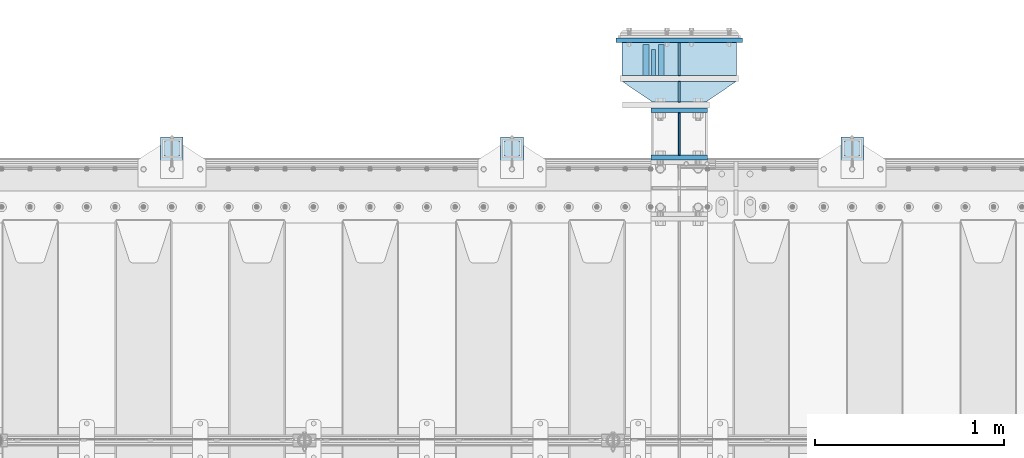
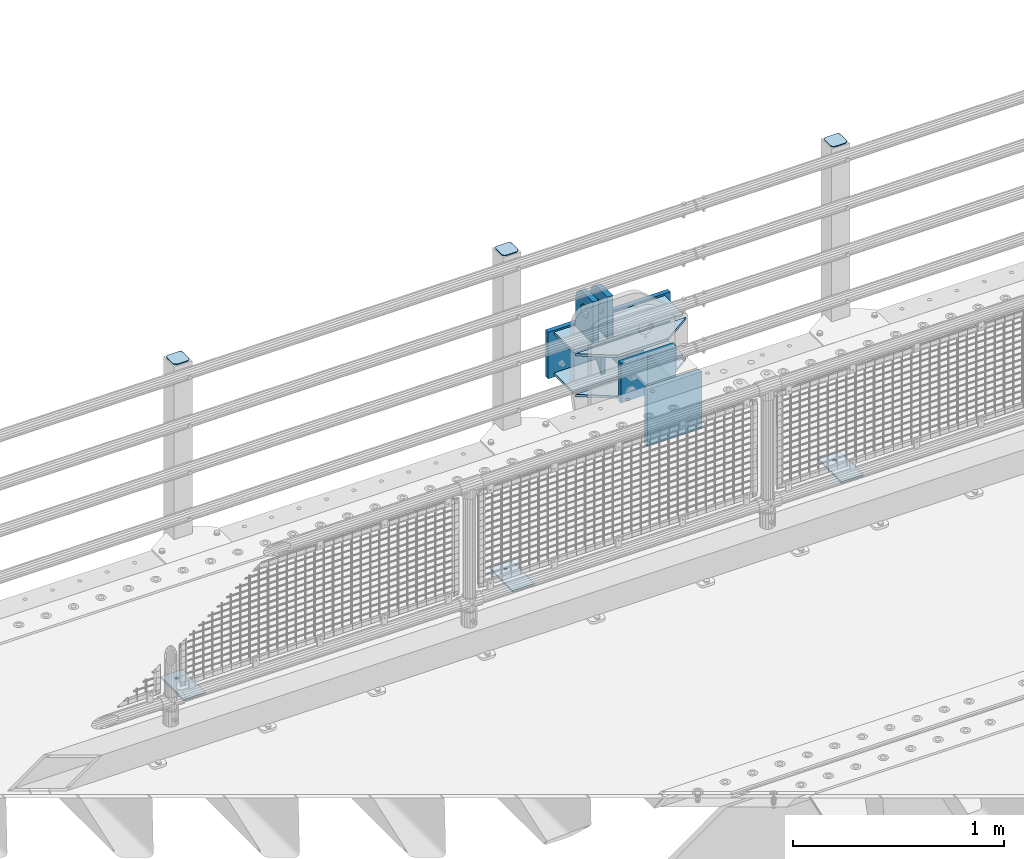
# One storey, part 239 of 270: 19 plates.
"""IFC2X3 building model written with IfcOpenShell, lengths in millimetres."""

from ifc_helpers import new_model, si_unit, frame, origin_with_axes, place, context, subcontext, project, spatial, faceted_brep, material, type_object, element, save


model = new_model("IFC2X3")

# Units and contexts
model_context = context("Model", 3, precision=1e-05, world=origin_with_axes())
body_context = subcontext(model_context, "Body", "Model", "MODEL_VIEW")
ifc_project = project(units=[si_unit("LENGTHUNIT", "METRE", prefix="MILLI"), si_unit("AREAUNIT", "SQUARE_METRE"), si_unit("VOLUMEUNIT", "CUBIC_METRE"), si_unit("MASSUNIT", "GRAM", prefix="KILO"), si_unit("TIMEUNIT", "SECOND"), si_unit("PLANEANGLEUNIT", "RADIAN"), si_unit("SOLIDANGLEUNIT", "STERADIAN"), si_unit("THERMODYNAMICTEMPERATUREUNIT", "DEGREE_CELSIUS"), si_unit("LUMINOUSINTENSITYUNIT", "LUMEN")], contexts=[model_context])

# Site, building, storey
site_placement = place(None, origin_with_axes())
site = spatial("IfcSite", under=ifc_project, at=site_placement, CompositionType="ELEMENT")
building_placement = place(site_placement, origin_with_axes())
building = spatial("IfcBuilding", under=site, at=building_placement, Name="Standard", CompositionType="ELEMENT")
storey_placement = place(building_placement, origin_with_axes())
storey = spatial("IfcBuildingStorey", under=building, at=storey_placement, Name="Undefined", CompositionType="ELEMENT", Elevation=0.0)

# Plates
ifc_material_1 = material(Name="STEEL/S355N")
plate_type_1 = type_object("IfcPlateType", PredefinedType="NOTDEFINED")
plate_1_placement = place(storey_placement, frame((13884.9999999931, -14837.4999999546, -350.000018205628), z_axis=(0.0, 0.0, 1.0), x_axis=(1.0, 0.0, 0.0)))
element("IfcPlate", 1, at=plate_1_placement, inside=storey, type_object=plate_type_1, material=ifc_material_1, context=body_context, shape_type="Brep", body=[
    faceted_brep([(0.0, -12.5, 0.0), (0.0, -12.5, 330.0), (0.0, 12.5, 330.0), (0.0, 12.5, 0.0), (300.0, -12.5, 330.0), (300.0, 12.5, 330.0), (300.0, -12.5, 0.0), (300.0, 12.5, 0.0)], [[[0, 1, 2, 3]], [[1, 4, 5, 2]], [[4, 6, 7, 5]], [[6, 0, 3, 7]], [[5, 7, 3, 2]], [[6, 4, 1, 0]]]),
])
plate_type_2 = type_object("IfcPlateType", PredefinedType="NOTDEFINED")
plate_2_placement = place(storey_placement, frame((14034.9999999931, -14824.9999999546, -346.000018205628), z_axis=(0.0, 1.0, 0.0), x_axis=(0.0, 0.0, 1.0)))
element("IfcPlate", 2, at=plate_2_placement, inside=storey, type_object=plate_type_2, material=ifc_material_1, context=body_context, shape_type="Brep", body=[
    faceted_brep([(0.0, -5.0, 0.0), (100.0, -5.0, 225.0), (100.0, 5.0, 225.0), (0.0, 5.0, 0.0), (322.0, -5.0, 225.0), (322.0, 5.0, 225.0), (322.0, -5.0, 0.0), (322.0, 5.0, 0.0)], [[[0, 1, 2, 3]], [[1, 4, 5, 2]], [[4, 6, 7, 5]], [[6, 0, 3, 7]], [[5, 7, 3, 2]], [[6, 4, 1, 0]]]),
])
plate_type_3 = type_object("IfcPlateType", PredefinedType="NOTDEFINED")
plate_3_placement = place(storey_placement, frame((13859.4999999931, -14404.9999999546, -10.0000182056285), z_axis=(0.0, 1.0, 0.0), x_axis=(0.0, 0.0, 1.0)))
element("IfcPlate", 3, at=plate_3_placement, inside=storey, type_object=plate_type_3, material=ifc_material_1, context=body_context, shape_type="Brep", body=[
    faceted_brep([(125.840713002492, 15.0, 114.183542702918), (125.840713002492, -15.0, 114.183542702918), (113.837049096098, -15.0, 106.162950903903), (113.837049096098, 15.0, 106.162950903903), (105.816457297082, -15.0, 94.1592869975084), (105.816457297082, 15.0, 94.1592869975084), (103.0, -15.0, 80.0), (103.0, 15.0, 80.0), (105.816457297082, -15.0, 65.8407130024916), (105.816457297082, 15.0, 65.8407130024916), (113.837049096098, -15.0, 53.837049096097), (113.837049096098, 15.0, 53.837049096097), (125.840713002492, -15.0, 45.8164572970818), (125.840713002492, 15.0, 45.8164572970818), (140.0, -15.0, 43.0), (140.0, 15.0, 43.0), (154.159286997508, -15.0, 45.8164572970818), (154.159286997508, 15.0, 45.8164572970818), (166.162950903902, -15.0, 53.837049096097), (166.162950903902, 15.0, 53.837049096097), (174.183542702918, -15.0, 65.8407130024916), (174.183542702918, 15.0, 65.8407130024916), (177.0, -15.0, 80.0), (177.0, 15.0, 80.0), (174.183542702918, -15.0, 94.1592869975084), (174.183542702918, 15.0, 94.1592869975084), (166.162950903902, -15.0, 106.162950903903), (166.162950903902, 15.0, 106.162950903903), (154.159286997508, -15.0, 114.183542702918), (154.159286997508, 15.0, 114.183542702918), (140.0, -15.0, 117.0), (140.0, 15.0, 117.0), (0.0, -15.0, 165.0), (170.0, -15.0, 165.0), (170.0, 15.0, 165.0), (0.0, 15.0, 165.0), (188.117333157176, -15.0, 162.614807840235), (188.117333157176, 15.0, 162.614807840235), (205.0, -15.0, 155.621778264911), (205.0, 15.0, 155.621778264911), (219.497474683058, -15.0, 144.497474683058), (219.497474683058, 15.0, 144.497474683058), (230.621778264911, -15.0, 130.0), (230.621778264911, 15.0, 130.0), (237.614807840235, -15.0, 113.117333157177), (237.614807840235, 15.0, 113.117333157177), (240.0, -15.0, 95.0), (240.0, 15.0, 95.0), (240.0, -15.0, 0.0), (240.0, 15.0, 0.0), (0.0, -15.0, 0.0), (0.0, 15.0, 0.0)], [[[0, 1, 2, 3]], [[3, 2, 4, 5]], [[5, 4, 6, 7]], [[7, 6, 8, 9]], [[9, 8, 10, 11]], [[11, 10, 12, 13]], [[13, 12, 14, 15]], [[15, 14, 16, 17]], [[17, 16, 18, 19]], [[19, 18, 20, 21]], [[21, 20, 22, 23]], [[23, 22, 24, 25]], [[25, 24, 26, 27]], [[27, 26, 28, 29]], [[29, 28, 30, 31]], [[31, 30, 1, 0]], [[32, 33, 34, 35]], [[33, 36, 37, 34]], [[36, 38, 39, 37]], [[38, 40, 41, 39]], [[40, 42, 43, 41]], [[42, 44, 45, 43]], [[44, 46, 47, 45]], [[46, 48, 49, 47]], [[48, 50, 51, 49]], [[34, 37, 39, 41, 43, 45, 47, 49, 51, 35], [3, 5, 7, 9, 11, 13, 15, 17, 19, 21, 23, 25, 27, 29, 31, 0]], [[50, 32, 35, 51]], [[48, 46, 44, 42, 40, 38, 36, 33, 32, 50], [26, 24, 22, 20, 18, 16, 14, 12, 10, 8, 6, 4, 2, 1, 30, 28]]]),
])
plate_4_placement = place(storey_placement, frame((13939.4999999931, -14404.9999999546, -10.0000182056285), z_axis=(0.0, 1.0, 0.0), x_axis=(0.0, 0.0, 1.0)))
element("IfcPlate", 4, at=plate_4_placement, inside=storey, type_object=plate_type_3, material=ifc_material_1, context=body_context, shape_type="Brep", body=[
    faceted_brep([(125.840713002492, 15.0, 114.183542702918), (125.840713002492, -15.0, 114.183542702918), (113.837049096098, -15.0, 106.162950903903), (113.837049096098, 15.0, 106.162950903903), (105.816457297082, -15.0, 94.1592869975084), (105.816457297082, 15.0, 94.1592869975084), (103.0, -15.0, 80.0), (103.0, 15.0, 80.0), (105.816457297082, -15.0, 65.8407130024916), (105.816457297082, 15.0, 65.8407130024916), (113.837049096098, -15.0, 53.837049096097), (113.837049096098, 15.0, 53.837049096097), (125.840713002492, -15.0, 45.8164572970818), (125.840713002492, 15.0, 45.8164572970818), (140.0, -15.0, 43.0), (140.0, 15.0, 43.0), (154.159286997508, -15.0, 45.8164572970818), (154.159286997508, 15.0, 45.8164572970818), (166.162950903902, -15.0, 53.837049096097), (166.162950903902, 15.0, 53.837049096097), (174.183542702918, -15.0, 65.8407130024916), (174.183542702918, 15.0, 65.8407130024916), (177.0, -15.0, 80.0), (177.0, 15.0, 80.0), (174.183542702918, -15.0, 94.1592869975084), (174.183542702918, 15.0, 94.1592869975084), (166.162950903902, -15.0, 106.162950903903), (166.162950903902, 15.0, 106.162950903903), (154.159286997508, -15.0, 114.183542702918), (154.159286997508, 15.0, 114.183542702918), (140.0, -15.0, 117.0), (140.0, 15.0, 117.0), (0.0, -15.0, 165.0), (170.0, -15.0, 165.0), (170.0, 15.0, 165.0), (0.0, 15.0, 165.0), (188.117333157176, -15.0, 162.614807840235), (188.117333157176, 15.0, 162.614807840235), (205.0, -15.0, 155.621778264911), (205.0, 15.0, 155.621778264911), (219.497474683058, -15.0, 144.497474683058), (219.497474683058, 15.0, 144.497474683058), (230.621778264911, -15.0, 130.0), (230.621778264911, 15.0, 130.0), (237.614807840235, -15.0, 113.117333157177), (237.614807840235, 15.0, 113.117333157177), (240.0, -15.0, 95.0), (240.0, 15.0, 95.0), (240.0, -15.0, 0.0), (240.0, 15.0, 0.0), (0.0, -15.0, 0.0), (0.0, 15.0, 0.0)], [[[0, 1, 2, 3]], [[3, 2, 4, 5]], [[5, 4, 6, 7]], [[7, 6, 8, 9]], [[9, 8, 10, 11]], [[11, 10, 12, 13]], [[13, 12, 14, 15]], [[15, 14, 16, 17]], [[17, 16, 18, 19]], [[19, 18, 20, 21]], [[21, 20, 22, 23]], [[23, 22, 24, 25]], [[25, 24, 26, 27]], [[27, 26, 28, 29]], [[29, 28, 30, 31]], [[31, 30, 1, 0]], [[32, 33, 34, 35]], [[33, 36, 37, 34]], [[36, 38, 39, 37]], [[38, 40, 41, 39]], [[40, 42, 43, 41]], [[42, 44, 45, 43]], [[44, 46, 47, 45]], [[46, 48, 49, 47]], [[48, 50, 51, 49]], [[34, 37, 39, 41, 43, 45, 47, 49, 51, 35], [3, 5, 7, 9, 11, 13, 15, 17, 19, 21, 23, 25, 27, 29, 31, 0]], [[50, 32, 35, 51]], [[48, 46, 44, 42, 40, 38, 36, 33, 32, 50], [26, 24, 22, 20, 18, 16, 14, 12, 10, 8, 6, 4, 2, 1, 30, 28]]]),
])
plate_type_4 = type_object("IfcPlateType", PredefinedType="NOTDEFINED")
plate_5_placement = place(storey_placement, frame((13899.4999999931, -14264.9999999546, -24.0000182055994), z_axis=(0.0, 0.0, -1.0), x_axis=(0.0, -1.0, 0.0)))
element("IfcPlate", 5, at=plate_5_placement, inside=storey, type_object=plate_type_4, material=ifc_material_1, context=body_context, shape_type="Brep", body=[
    faceted_brep([(0.0, -10.0, 0.0), (140.0, -10.0, 180.0), (140.0, 10.0, 180.0), (0.0, 10.0, 0.0), (140.0, -10.0, -1.81898940354586e-12), (140.0, 10.0, -1.81898940354586e-12)], [[[0, 1, 2, 3]], [[1, 4, 5, 2]], [[4, 0, 3, 5]], [[5, 3, 2]], [[4, 1, 0]]]),
])
ifc_material_2 = material(Name="STEEL/S355J2")
plate_type_5 = type_object("IfcPlateType", PredefinedType="NOTDEFINED")
for number, where, z_axis, x_axis in (
    (6, (14890.0000000001, -14949.9999999998, -850.000000000002), (0.0, 1.0, 0.0), (1.0, 0.0, 0.0)),
    (7, (13090.0000000001, -14949.9999999998, -850.000000000002), (0.0, 1.0, 0.0), (1.0, 0.0, 0.0)),
    (8, (11290.0000000001, -14949.9999999998, -850.000000000002), (0.0, 1.0, 0.0), (1.0, 0.0, 0.0)),
):
    element("IfcPlate", number, at=place(storey_placement, frame(where, z_axis=z_axis, x_axis=x_axis)), inside=storey, type_object=plate_type_5, material=ifc_material_2, context=body_context, shape_type="Brep", body=[
        faceted_brep([(66.3639610305399, -5.0, 163.636038969114), (66.3639610305399, 5.0, 163.636038969114), (59.9999999998618, 5.0, 160.999999999793), (59.9999999998618, -5.0, 160.999999999793), (53.6360389691836, 5.0, 163.636038969114), (53.6360389691836, -5.0, 163.636038969114), (50.9999999998618, 5.0, 169.999999999793), (50.9999999998618, -5.0, 169.999999999793), (53.6360389691836, 5.0, 176.363961030471), (53.6360389691836, -5.0, 176.363961030471), (59.9999999998618, 5.0, 178.999999999793), (59.9999999998618, -5.0, 178.999999999793), (66.3639610305399, 5.0, 176.363961030471), (66.3639610305399, -5.0, 176.363961030471), (68.9999999998618, 5.0, 169.999999999793), (68.9999999998618, -5.0, 169.999999999793), (120.0, -5.0, 0.0), (120.0, -5.0, 220.0), (0.0, -5.0, 220.0), (0.0, -5.0, 0.0), (0.0, 5.0, 0.0), (120.0, 5.0, 0.0), (120.0, 5.0, 220.0), (0.0, 5.0, 220.0)], [[[0, 1, 2, 3]], [[3, 2, 4, 5]], [[5, 4, 6, 7]], [[7, 6, 8, 9]], [[9, 8, 10, 11]], [[11, 10, 12, 13]], [[13, 12, 14, 15]], [[15, 14, 1, 0]], [[16, 17, 18, 19], [3, 5, 7, 9, 11, 13, 15, 0]], [[16, 19, 20, 21]], [[17, 16, 21, 22]], [[18, 17, 22, 23]], [[19, 18, 23, 20]], [[22, 21, 20, 23], [10, 8, 6, 4, 2, 1, 14, 12]]]),
    ])
plate_type_6 = type_object("IfcPlateType", PredefinedType="NOTDEFINED")
plate_6_placement = place(storey_placement, frame((14994.0000000001, -14833.9999999998, 1012.50000000001), z_axis=(0.0, 1.0, 0.0), x_axis=(-1.0, 0.0, 0.0)))
element("IfcPlate", 9, at=plate_6_placement, inside=storey, type_object=plate_type_6, material=ifc_material_2, context=body_context, shape_type="Brep", body=[
    faceted_brep([(0.0, -2.5, 19.0), (0.0, -2.5, 69.0), (0.0, 2.5, 69.0), (0.0, 2.5, 19.0), (0.476369668544066, -2.5, 73.2278977451697), (0.476369668544066, 2.5, 73.2278977451697), (1.88159150985302, -2.5, 77.2437910432327), (1.88159150985302, 2.5, 77.2437910432327), (4.14520183310742, -2.5, 80.8463062353167), (4.14520183310742, 2.5, 80.8463062353167), (7.15369376468516, -2.5, 83.8547981668926), (7.15369376468516, 2.5, 83.8547981668926), (10.7562089567655, -2.5, 86.1184084901452), (10.7562089567655, 2.5, 86.1184084901452), (14.7721022548285, -2.5, 87.5236303314541), (14.7721022548285, 2.5, 87.5236303314541), (19.0, -2.5, 88.0), (19.0, 2.5, 88.0), (69.0, -2.5, 88.0), (69.0, 2.5, 88.0), (73.2278977451715, -2.5, 87.5236303314541), (73.2278977451715, 2.5, 87.5236303314541), (77.2437910432345, -2.5, 86.1184084901452), (77.2437910432345, 2.5, 86.1184084901452), (80.8463062353148, -2.5, 83.8547981668926), (80.8463062353148, 2.5, 83.8547981668926), (83.8547981668926, -2.5, 80.8463062353167), (83.8547981668926, 2.5, 80.8463062353167), (86.118408490147, -2.5, 77.2437910432345), (86.118408490147, 2.5, 77.2437910432345), (87.5236303314559, -2.5, 73.2278977451697), (87.5236303314559, 2.5, 73.2278977451697), (88.0, -2.5, 69.0), (88.0, 2.5, 69.0), (88.0, -2.5, 19.0), (88.0, 2.5, 19.0), (87.5236303314559, -2.5, 14.7721022548303), (87.5236303314559, 2.5, 14.7721022548303), (86.118408490147, -2.5, 10.7562089567673), (86.118408490147, 2.5, 10.7562089567673), (83.8547981668926, -2.5, 7.15369376468334), (83.8547981668926, 2.5, 7.15369376468334), (80.8463062353148, -2.5, 4.14520183310742), (80.8463062353148, 2.5, 4.14520183310742), (77.2437910432345, -2.5, 1.88159150985484), (77.2437910432345, 2.5, 1.88159150985484), (73.2278977451715, -2.5, 0.476369668545885), (73.2278977451715, 2.5, 0.476369668545885), (69.0, -2.5, 0.0), (69.0, 2.5, 0.0), (19.0, -2.5, 0.0), (19.0, 2.5, 0.0), (14.7721022548285, -2.5, 0.476369668545885), (14.7721022548285, 2.5, 0.476369668545885), (10.7562089567655, -2.5, 1.88159150985484), (10.7562089567655, 2.5, 1.88159150985484), (7.15369376468516, -2.5, 4.14520183310742), (7.15369376468516, 2.5, 4.14520183310742), (4.14520183310742, -2.5, 7.15369376468334), (4.14520183310742, 2.5, 7.15369376468334), (1.88159150985302, -2.5, 10.7562089567673), (1.88159150985302, 2.5, 10.7562089567673), (0.476369668544066, -2.5, 14.7721022548303), (0.476369668544066, 2.5, 14.7721022548303)], [[[0, 1, 2, 3]], [[1, 4, 5, 2]], [[4, 6, 7, 5]], [[6, 8, 9, 7]], [[8, 10, 11, 9]], [[10, 12, 13, 11]], [[12, 14, 15, 13]], [[14, 16, 17, 15]], [[16, 18, 19, 17]], [[18, 20, 21, 19]], [[20, 22, 23, 21]], [[22, 24, 25, 23]], [[24, 26, 27, 25]], [[26, 28, 29, 27]], [[28, 30, 31, 29]], [[30, 32, 33, 31]], [[32, 34, 35, 33]], [[34, 36, 37, 35]], [[36, 38, 39, 37]], [[38, 40, 41, 39]], [[40, 42, 43, 41]], [[42, 44, 45, 43]], [[44, 46, 47, 45]], [[46, 48, 49, 47]], [[48, 50, 51, 49]], [[50, 52, 53, 51]], [[52, 54, 55, 53]], [[54, 56, 57, 55]], [[56, 58, 59, 57]], [[58, 60, 61, 59]], [[60, 62, 63, 61]], [[62, 0, 3, 63]], [[5, 7, 9, 11, 13, 15, 17, 19, 21, 23, 25, 27, 29, 31, 33, 35, 37, 39, 41, 43, 45, 47, 49, 51, 53, 55, 57, 59, 61, 63, 3, 2]], [[62, 60, 58, 56, 54, 52, 50, 48, 46, 44, 42, 40, 38, 36, 34, 32, 30, 28, 26, 24, 22, 20, 18, 16, 14, 12, 10, 8, 6, 4, 1, 0]]]),
])
plate_7_placement = place(storey_placement, frame((13194.0000000001, -14833.9999999998, 1012.50000000001), z_axis=(0.0, 1.0, 0.0), x_axis=(-1.0, 0.0, 0.0)))
element("IfcPlate", 10, at=plate_7_placement, inside=storey, type_object=plate_type_6, material=ifc_material_2, context=body_context, shape_type="Brep", body=[
    faceted_brep([(0.0, -2.5, 19.0), (0.0, -2.5, 69.0), (0.0, 2.5, 69.0), (0.0, 2.5, 19.0), (0.476369668544066, -2.5, 73.2278977451697), (0.476369668544066, 2.5, 73.2278977451697), (1.88159150985302, -2.5, 77.2437910432327), (1.88159150985302, 2.5, 77.2437910432327), (4.14520183310742, -2.5, 80.8463062353167), (4.14520183310742, 2.5, 80.8463062353167), (7.15369376468516, -2.5, 83.8547981668926), (7.15369376468516, 2.5, 83.8547981668926), (10.7562089567655, -2.5, 86.1184084901452), (10.7562089567655, 2.5, 86.1184084901452), (14.7721022548285, -2.5, 87.5236303314541), (14.7721022548285, 2.5, 87.5236303314541), (19.0, -2.5, 88.0), (19.0, 2.5, 88.0), (69.0, -2.5, 88.0), (69.0, 2.5, 88.0), (73.2278977451715, -2.5, 87.5236303314541), (73.2278977451715, 2.5, 87.5236303314541), (77.2437910432345, -2.5, 86.1184084901452), (77.2437910432345, 2.5, 86.1184084901452), (80.8463062353148, -2.5, 83.8547981668926), (80.8463062353148, 2.5, 83.8547981668926), (83.8547981668926, -2.5, 80.8463062353167), (83.8547981668926, 2.5, 80.8463062353167), (86.118408490147, -2.5, 77.2437910432345), (86.118408490147, 2.5, 77.2437910432345), (87.5236303314559, -2.5, 73.2278977451697), (87.5236303314559, 2.5, 73.2278977451697), (88.0, -2.5, 69.0), (88.0, 2.5, 69.0), (88.0, -2.5, 19.0), (88.0, 2.5, 19.0), (87.5236303314559, -2.5, 14.7721022548303), (87.5236303314559, 2.5, 14.7721022548303), (86.118408490147, -2.5, 10.7562089567673), (86.118408490147, 2.5, 10.7562089567673), (83.8547981668926, -2.5, 7.15369376468334), (83.8547981668926, 2.5, 7.15369376468334), (80.8463062353148, -2.5, 4.14520183310742), (80.8463062353148, 2.5, 4.14520183310742), (77.2437910432345, -2.5, 1.88159150985484), (77.2437910432345, 2.5, 1.88159150985484), (73.2278977451715, -2.5, 0.476369668545885), (73.2278977451715, 2.5, 0.476369668545885), (69.0, -2.5, 0.0), (69.0, 2.5, 0.0), (19.0, -2.5, 0.0), (19.0, 2.5, 0.0), (14.7721022548285, -2.5, 0.476369668545885), (14.7721022548285, 2.5, 0.476369668545885), (10.7562089567655, -2.5, 1.88159150985484), (10.7562089567655, 2.5, 1.88159150985484), (7.15369376468516, -2.5, 4.14520183310742), (7.15369376468516, 2.5, 4.14520183310742), (4.14520183310742, -2.5, 7.15369376468334), (4.14520183310742, 2.5, 7.15369376468334), (1.88159150985302, -2.5, 10.7562089567673), (1.88159150985302, 2.5, 10.7562089567673), (0.476369668544066, -2.5, 14.7721022548303), (0.476369668544066, 2.5, 14.7721022548303)], [[[0, 1, 2, 3]], [[1, 4, 5, 2]], [[4, 6, 7, 5]], [[6, 8, 9, 7]], [[8, 10, 11, 9]], [[10, 12, 13, 11]], [[12, 14, 15, 13]], [[14, 16, 17, 15]], [[16, 18, 19, 17]], [[18, 20, 21, 19]], [[20, 22, 23, 21]], [[22, 24, 25, 23]], [[24, 26, 27, 25]], [[26, 28, 29, 27]], [[28, 30, 31, 29]], [[30, 32, 33, 31]], [[32, 34, 35, 33]], [[34, 36, 37, 35]], [[36, 38, 39, 37]], [[38, 40, 41, 39]], [[40, 42, 43, 41]], [[42, 44, 45, 43]], [[44, 46, 47, 45]], [[46, 48, 49, 47]], [[48, 50, 51, 49]], [[50, 52, 53, 51]], [[52, 54, 55, 53]], [[54, 56, 57, 55]], [[56, 58, 59, 57]], [[58, 60, 61, 59]], [[60, 62, 63, 61]], [[62, 0, 3, 63]], [[5, 7, 9, 11, 13, 15, 17, 19, 21, 23, 25, 27, 29, 31, 33, 35, 37, 39, 41, 43, 45, 47, 49, 51, 53, 55, 57, 59, 61, 63, 3, 2]], [[62, 60, 58, 56, 54, 52, 50, 48, 46, 44, 42, 40, 38, 36, 34, 32, 30, 28, 26, 24, 22, 20, 18, 16, 14, 12, 10, 8, 6, 4, 1, 0]]]),
])
plate_8_placement = place(storey_placement, frame((11394.0000000001, -14833.9999999998, 1012.50000000001), z_axis=(0.0, 1.0, 0.0), x_axis=(-1.0, 0.0, 0.0)))
element("IfcPlate", 11, at=plate_8_placement, inside=storey, type_object=plate_type_6, material=ifc_material_2, context=body_context, shape_type="Brep", body=[
    faceted_brep([(0.0, -2.5, 19.0), (0.0, -2.5, 69.0), (0.0, 2.5, 69.0), (0.0, 2.5, 19.0), (0.476369668544066, -2.5, 73.2278977451697), (0.476369668544066, 2.5, 73.2278977451697), (1.88159150985302, -2.5, 77.2437910432327), (1.88159150985302, 2.5, 77.2437910432327), (4.14520183310742, -2.5, 80.8463062353167), (4.14520183310742, 2.5, 80.8463062353167), (7.15369376468516, -2.5, 83.8547981668926), (7.15369376468516, 2.5, 83.8547981668926), (10.7562089567655, -2.5, 86.1184084901452), (10.7562089567655, 2.5, 86.1184084901452), (14.7721022548285, -2.5, 87.5236303314541), (14.7721022548285, 2.5, 87.5236303314541), (19.0, -2.5, 88.0), (19.0, 2.5, 88.0), (69.0, -2.5, 88.0), (69.0, 2.5, 88.0), (73.2278977451715, -2.5, 87.5236303314541), (73.2278977451715, 2.5, 87.5236303314541), (77.2437910432345, -2.5, 86.1184084901452), (77.2437910432345, 2.5, 86.1184084901452), (80.8463062353148, -2.5, 83.8547981668926), (80.8463062353148, 2.5, 83.8547981668926), (83.8547981668926, -2.5, 80.8463062353167), (83.8547981668926, 2.5, 80.8463062353167), (86.118408490147, -2.5, 77.2437910432345), (86.118408490147, 2.5, 77.2437910432345), (87.5236303314559, -2.5, 73.2278977451697), (87.5236303314559, 2.5, 73.2278977451697), (88.0, -2.5, 69.0), (88.0, 2.5, 69.0), (88.0, -2.5, 19.0), (88.0, 2.5, 19.0), (87.5236303314559, -2.5, 14.7721022548303), (87.5236303314559, 2.5, 14.7721022548303), (86.118408490147, -2.5, 10.7562089567673), (86.118408490147, 2.5, 10.7562089567673), (83.8547981668926, -2.5, 7.15369376468334), (83.8547981668926, 2.5, 7.15369376468334), (80.8463062353148, -2.5, 4.14520183310742), (80.8463062353148, 2.5, 4.14520183310742), (77.2437910432345, -2.5, 1.88159150985484), (77.2437910432345, 2.5, 1.88159150985484), (73.2278977451715, -2.5, 0.476369668545885), (73.2278977451715, 2.5, 0.476369668545885), (69.0, -2.5, 0.0), (69.0, 2.5, 0.0), (19.0, -2.5, 0.0), (19.0, 2.5, 0.0), (14.7721022548285, -2.5, 0.476369668545885), (14.7721022548285, 2.5, 0.476369668545885), (10.7562089567655, -2.5, 1.88159150985484), (10.7562089567655, 2.5, 1.88159150985484), (7.15369376468516, -2.5, 4.14520183310742), (7.15369376468516, 2.5, 4.14520183310742), (4.14520183310742, -2.5, 7.15369376468334), (4.14520183310742, 2.5, 7.15369376468334), (1.88159150985302, -2.5, 10.7562089567673), (1.88159150985302, 2.5, 10.7562089567673), (0.476369668544066, -2.5, 14.7721022548303), (0.476369668544066, 2.5, 14.7721022548303)], [[[0, 1, 2, 3]], [[1, 4, 5, 2]], [[4, 6, 7, 5]], [[6, 8, 9, 7]], [[8, 10, 11, 9]], [[10, 12, 13, 11]], [[12, 14, 15, 13]], [[14, 16, 17, 15]], [[16, 18, 19, 17]], [[18, 20, 21, 19]], [[20, 22, 23, 21]], [[22, 24, 25, 23]], [[24, 26, 27, 25]], [[26, 28, 29, 27]], [[28, 30, 31, 29]], [[30, 32, 33, 31]], [[32, 34, 35, 33]], [[34, 36, 37, 35]], [[36, 38, 39, 37]], [[38, 40, 41, 39]], [[40, 42, 43, 41]], [[42, 44, 45, 43]], [[44, 46, 47, 45]], [[46, 48, 49, 47]], [[48, 50, 51, 49]], [[50, 52, 53, 51]], [[52, 54, 55, 53]], [[54, 56, 57, 55]], [[56, 58, 59, 57]], [[58, 60, 61, 59]], [[60, 62, 63, 61]], [[62, 0, 3, 63]], [[5, 7, 9, 11, 13, 15, 17, 19, 21, 23, 25, 27, 29, 31, 33, 35, 37, 39, 41, 43, 45, 47, 49, 51, 53, 55, 57, 59, 61, 63, 3, 2]], [[62, 60, 58, 56, 54, 52, 50, 48, 46, 44, 42, 40, 38, 36, 34, 32, 30, 28, 26, 24, 22, 20, 18, 16, 14, 12, 10, 8, 6, 4, 1, 0]]]),
])
plate_type_7 = type_object("IfcPlateType", PredefinedType="NOTDEFINED")
plate_9_placement = place(storey_placement, frame((14034.9999999931, -14229.9999999546, -24.0000182056285), z_axis=(0.0, 0.0, -1.0), x_axis=(0.0, -1.0, 0.0)))
element("IfcPlate", 12, at=plate_9_placement, inside=storey, type_object=plate_type_7, material=ifc_material_1, context=body_context, shape_type="Brep", body=[
    faceted_brep([(0.0, -5.0, 0.0), (0.0, -5.0, 222.0), (0.0, 5.0, 222.0), (0.0, 5.0, 0.0), (175.0, -5.0, 222.0), (175.0, 5.0, 222.0), (175.0, -5.0, 0.0), (175.0, 5.0, 0.0)], [[[0, 1, 2, 3]], [[1, 4, 5, 2]], [[4, 6, 7, 5]], [[6, 0, 3, 7]], [[5, 7, 3, 2]], [[6, 4, 1, 0]]]),
])
plate_type_8 = type_object("IfcPlateType", PredefinedType="NOTDEFINED")
plate_10_placement = place(storey_placement, frame((14034.9999999931, -14434.9999999546, -24.0000182056285), z_axis=(0.0, 0.0, -1.0), x_axis=(0.0, -1.0, 0.0)))
element("IfcPlate", 13, at=plate_10_placement, inside=storey, type_object=plate_type_8, material=ifc_material_1, context=body_context, shape_type="Brep", body=[
    faceted_brep([(0.0, -5.0, 0.0), (0.0, -5.0, 222.0), (0.0, 5.0, 222.0), (0.0, 5.0, 0.0), (110.0, -5.0, 222.0), (110.0, 5.0, 222.0), (110.0, -5.0, 0.0), (110.0, 5.0, 0.0)], [[[0, 1, 2, 3]], [[1, 4, 5, 2]], [[4, 6, 7, 5]], [[6, 0, 3, 7]], [[5, 7, 3, 2]], [[6, 4, 1, 0]]]),
])
ifc_material_3 = material()
plate_type_9 = type_object("IfcPlateType", PredefinedType="NOTDEFINED")
for number, where, z_axis, x_axis in (
    (14, (14337.4999999931, -14404.9999999546, -17.0000182056285), (0.0, 1.0, 0.0), (-1.0, 0.0, 0.0)),
    (15, (14337.4999999931, -14404.9999999546, -253.000018205628), (0.0, 1.0, 0.0), (-1.0, 0.0, 0.0)),
):
    element("IfcPlate", number, at=place(storey_placement, frame(where, z_axis=z_axis, x_axis=x_axis)), inside=storey, type_object=plate_type_9, material=ifc_material_3, context=body_context, shape_type="Brep", body=[
        faceted_brep([(0.0, -7.0, 0.0), (0.0, -7.0, 175.0), (0.0, 7.0, 175.0), (0.0, 7.0, 0.0), (605.0, -7.0, 175.0), (605.0, 7.0, 175.0), (605.0, -7.0, 0.0), (605.0, 7.0, 0.0)], [[[0, 1, 2, 3]], [[1, 4, 5, 2]], [[4, 6, 7, 5]], [[6, 0, 3, 7]], [[5, 7, 3, 2]], [[6, 4, 1, 0]]]),
    ])
plate_type_10 = type_object("IfcPlateType", PredefinedType="NOTDEFINED")
for number, where, z_axis, x_axis in (
    (16, (14337.4999999931, -14434.9999999546, -17.0000182056285), (-0.560566412034006, 0.828109472050236, 0.0), (-0.828109472050238, -0.560566412034004, 0.0)),
    (17, (14337.4999999931, -14434.9999999546, -253.000018205628), (-0.560566412034006, 0.828109472050236, 0.0), (-0.828109472050238, -0.560566412034004, 0.0)),
):
    element("IfcPlate", number, at=place(storey_placement, frame(where, z_axis=z_axis, x_axis=x_axis)), inside=storey, type_object=plate_type_10, material=ifc_material_1, context=body_context, shape_type="Brep", body=[
        faceted_brep([(0.0, -7.0, 0.0), (501.006225585938, -7.0, 339.142669677731), (501.006225585938, 7.0, 339.142669677731), (0.0, 7.0, 0.0), (428.100738525392, -7.0, 156.95860290527), (428.100738525392, 7.0, 156.95860290527), (196.230087280276, -7.0, -4.00177668780088e-11), (196.230087280276, 7.0, -4.00177668780088e-11)], [[[0, 1, 2, 3]], [[1, 4, 5, 2]], [[4, 6, 7, 5]], [[6, 0, 3, 7]], [[5, 7, 3, 2]], [[6, 4, 1, 0]]]),
    ])
plate_type_11 = type_object("IfcPlateType", PredefinedType="NOTDEFINED")
plate_11_placement = place(storey_placement, frame((14369.9999999931, -14217.4999999546, -1.82056285211729e-05), z_axis=(0.0, 0.0, -1.0), x_axis=(-1.0, 0.0, 0.0)))
element("IfcPlate", 18, at=plate_11_placement, inside=storey, type_object=plate_type_11, material=ifc_material_1, context=body_context, shape_type="Brep", body=[
    faceted_brep([(0.0, -12.5, 0.0), (0.0, -12.5, 270.0), (0.0, 12.5, 270.0), (0.0, 12.5, 0.0), (670.0, -12.5, 270.0), (670.0, 12.5, 270.0), (670.0, -12.5, 0.0), (670.0, 12.5, 0.0)], [[[0, 1, 2, 3]], [[1, 4, 5, 2]], [[4, 6, 7, 5]], [[6, 0, 3, 7]], [[5, 7, 3, 2]], [[6, 4, 1, 0]]]),
])
plate_type_12 = type_object("IfcPlateType", PredefinedType="NOTDEFINED")
plate_12_placement = place(storey_placement, frame((13884.9999999931, -14587.4999999546, -250.000018205628), z_axis=(0.0, 0.0, 1.0), x_axis=(1.0, 0.0, 0.0)))
element("IfcPlate", 19, at=plate_12_placement, inside=storey, type_object=plate_type_12, material=ifc_material_1, context=body_context, shape_type="Brep", body=[
    faceted_brep([(0.0, -12.5, 0.0), (0.0, -12.5, 230.0), (0.0, 12.5, 230.0), (0.0, 12.5, 0.0), (300.0, -12.5, 230.0), (300.0, 12.5, 230.0), (300.0, -12.5, 0.0), (300.0, 12.5, 0.0)], [[[0, 1, 2, 3]], [[1, 4, 5, 2]], [[4, 6, 7, 5]], [[6, 0, 3, 7]], [[5, 7, 3, 2]], [[6, 4, 1, 0]]]),
])

save(model, "model.ifc")
